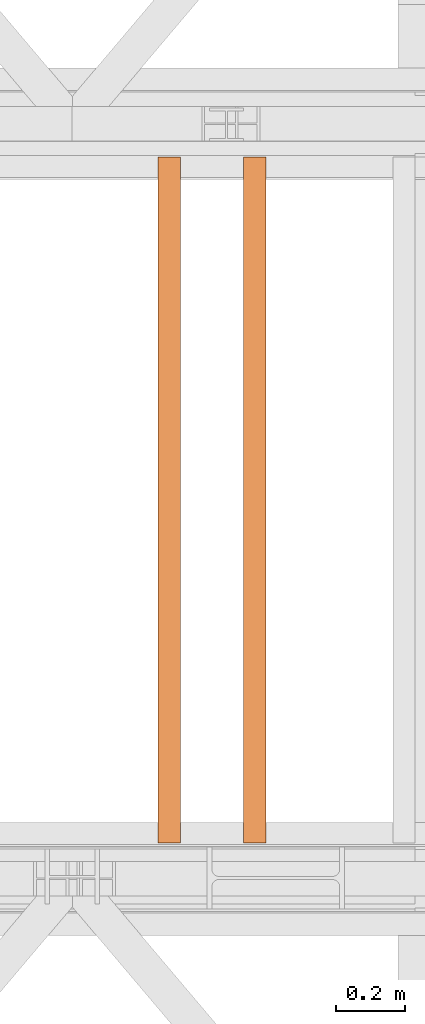
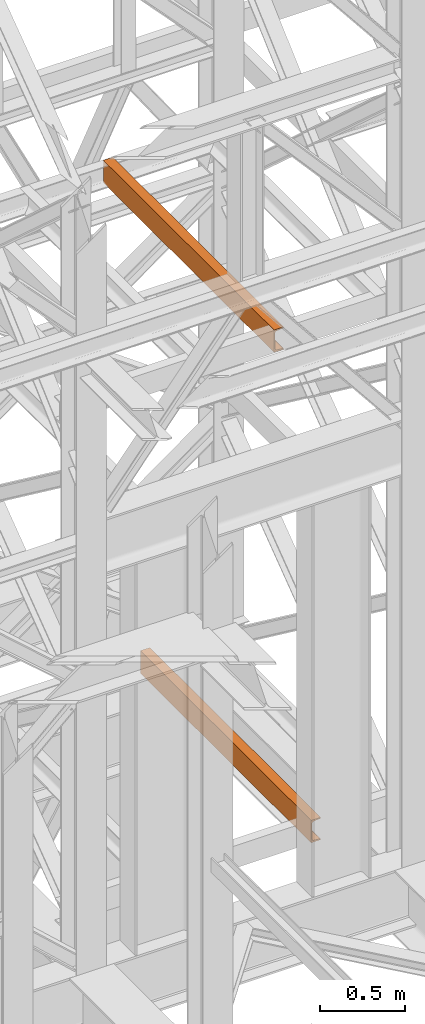
# One storey, part 181 of 208: 2 proxies.
"""IFC2X3 building model written with IfcOpenShell, lengths in millimetres."""

from ifc_helpers import new_model, entity, si_unit, converted_unit, frame, origin, origin_with_axes, place, context, subcontext, project, spatial, faceted_brep, element, save


model = new_model("IFC2X3")

# Units and contexts
model_context = context("Model", 3, precision=1e-05, world=origin())
plan_context = context("Plan", 3, precision=1e-05, world=origin())
body_context = subcontext(model_context, "Body", "Model", "MODEL_VIEW")
ifc_project = project(units=[si_unit("LENGTHUNIT", "METRE", prefix="MILLI"), converted_unit("PLANEANGLEUNIT", "DEGREE", entity("IfcPlaneAngleMeasure", 0.0174532925199433), si_unit("PLANEANGLEUNIT", "RADIAN"), dimensions=[0, 0, 0, 0, 0, 0, 0]), si_unit("AREAUNIT", "SQUARE_METRE"), si_unit("VOLUMEUNIT", "CUBIC_METRE")], contexts=[model_context, plan_context])

# Building, storey
building_placement = place(None, origin())
building = spatial("IfcBuilding", under=ifc_project, at=building_placement, CompositionType="COMPLEX")
storey_placement = place(building_placement, origin_with_axes())
storey = spatial("IfcBuildingStorey", under=building, at=storey_placement, Name="Geschoss", CompositionType="ELEMENT")

# Proxies
proxy_1_placement = place(storey_placement, frame((7943.302373794972, -15857.57439274273, 9109.989999999998), z_axis=(0.0, 0.0, 1.0), x_axis=(1.0, 0.0, 0.0)))
element("IfcBuildingElementProxy", 1, at=proxy_1_placement, inside=storey, context=body_context, shape_type="Brep", body=[
    faceted_brep([(0.01000000000203727, 2000.009997019768, 160.0100000000002), (65.01000000000204, 2000.009997019768, 160.0100000000002), (65.01000000000022, 0.01000000000021828, 160.0100000000002), (0.01000000000021828, 0.01000000000021828, 160.0100000000002), (65.01000000000204, 2000.009997019768, 160.0100000000002), (65.01000000000204, 2000.009997019768, 156.8875719297539), (65.01000000000022, 0.01000000000021828, 156.8875719297539), (65.01000000000022, 0.01000000000021828, 160.0100000000002), (65.01000000000204, 2000.009997019768, 156.8875719297539), (64.76726342282927, 2000.009997019768, 155.2717110918293), (64.76726342282745, 0.01000000000021828, 155.2717110918293), (65.01000000000022, 0.01000000000021828, 156.8875719297539), (64.76726342282927, 2000.009997019768, 155.2717110918293), (64.06053228585733, 2000.009997019768, 153.7984655565542), (64.06053228585915, 0.01000000000021828, 153.7984655565542), (64.76726342282745, 0.01000000000021828, 155.2717110918293), (64.06053228585733, 2000.009997019768, 153.7984655565542), (62.95215163847024, 2000.009997019768, 152.5978732961266), (62.95215163846842, 0.01000000000021828, 152.5978732961266), (64.06053228585915, 0.01000000000021828, 153.7984655565542), (62.95215163847024, 2000.009997019768, 152.5978732961266), (61.53995641148504, 2000.009997019768, 151.7759086082897), (61.53995641148322, 0.01000000000021828, 151.7759086082897), (62.95215163846842, 0.01000000000021828, 152.5978732961266), (61.53995641148504, 2000.009997019768, 151.7759086082897), (59.9485987225562, 2000.009997019768, 151.4050878978051), (59.94859872255438, 0.01000000000021828, 151.4050878978051), (61.53995641148322, 0.01000000000021828, 151.7759086082897), (59.9485987225562, 2000.009997019768, 151.4050878978051), (17.1726751660317, 2000.009997019768, 147.9830140132835), (17.17267516602988, 0.01000000000021828, 147.9830140132835), (59.94859872255438, 0.01000000000021828, 151.4050878978051), (17.1726751660317, 2000.009997019768, 147.9830140132835), (14.20840820801095, 2000.009997019768, 147.318026761528), (14.20840820800913, 0.01000000000021828, 147.318026761528), (17.17267516602988, 0.01000000000021828, 147.9830140132835), (14.20840820801095, 2000.009997019768, 147.318026761528), (11.43861959928836, 2000.009997019768, 145.7058782528511), (11.43861959929018, 0.01000000000021828, 145.7058782528511), (14.20840820800913, 0.01000000000021828, 147.318026761528), (11.43861959928836, 2000.009997019768, 145.7058782528511), (9.3226201815487, 2000.009997019768, 143.4138384829421), (9.322620181546881, 0.01000000000021828, 143.4138384829421), (11.43861959929018, 0.01000000000021828, 145.7058782528511), (9.3226201815487, 2000.009997019768, 143.4138384829421), (7.973406192788389, 2000.009997019768, 140.6012788246917), (7.97340619278657, 0.01000000000021828, 140.6012788246917), (9.322620181546881, 0.01000000000021828, 143.4138384829421), (7.973406192788389, 2000.009997019768, 140.6012788246917), (7.510000000002037, 2000.009997019768, 137.5164535886543), (7.510000000000218, 0.01000000000021828, 137.5164535886543), (7.97340619278657, 0.01000000000021828, 140.6012788246917), (7.510000000002037, 2000.009997019768, 137.5164535886543), (7.510000000002037, 2000.009997019768, 22.503546411348), (7.510000000000218, 0.01000000000021828, 22.503546411348), (7.510000000000218, 0.01000000000021828, 137.5164535886543), (7.510000000002037, 2000.009997019768, 22.503546411348), (7.973406192788389, 2000.009997019768, 19.41872117530875), (7.97340619278657, 0.01000000000021828, 19.41872117530875), (7.510000000000218, 0.01000000000021828, 22.503546411348), (7.973406192788389, 2000.009997019768, 19.41872117530875), (9.3226201815487, 2000.009997019768, 16.60616151705835), (9.322620181546881, 0.01000000000021828, 16.60616151705835), (7.97340619278657, 0.01000000000021828, 19.41872117530875), (9.3226201815487, 2000.009997019768, 16.60616151705835), (11.43861959928836, 2000.009997019768, 14.31412174714933), (11.43861959929018, 0.01000000000021828, 14.31412174714933), (9.322620181546881, 0.01000000000021828, 16.60616151705835), (11.43861959928836, 2000.009997019768, 14.31412174714933), (14.13462866898408, 2000.009997019768, 12.74491643400688), (14.1346286689859, 0.01000000000021828, 12.74491643400688), (11.43861959929018, 0.01000000000021828, 14.31412174714933), (14.13462866898408, 2000.009997019768, 12.74491643400688), (17.1726751660317, 2000.009997019768, 12.03698598671872), (17.17267516602988, 0.01000000000021828, 12.03698598671872), (14.1346286689859, 0.01000000000021828, 12.74491643400688), (17.1726751660317, 2000.009997019768, 12.03698598671872), (59.9485987225562, 2000.009997019768, 8.614912102195376), (59.94859872255438, 0.01000000000021828, 8.614912102195376), (17.17267516602988, 0.01000000000021828, 12.03698598671872), (59.9485987225562, 2000.009997019768, 8.614912102195376), (61.53995641148504, 2000.009997019768, 8.244091391710754), (61.53995641148322, 0.01000000000021828, 8.244091391710754), (59.94859872255438, 0.01000000000021828, 8.614912102195376), (61.53995641148504, 2000.009997019768, 8.244091391710754), (62.95215163847024, 2000.009997019768, 7.422126703873801), (62.95215163846842, 0.01000000000021828, 7.422126703873801), (61.53995641148322, 0.01000000000021828, 8.244091391710754), (62.95215163847024, 2000.009997019768, 7.422126703873801), (64.06053228585733, 2000.009997019768, 6.221534443446217), (64.06053228585915, 0.01000000000021828, 6.221534443446217), (62.95215163846842, 0.01000000000021828, 7.422126703873801), (64.06053228585733, 2000.009997019768, 6.221534443446217), (64.76726342282927, 2000.009997019768, 4.748288908172981), (64.76726342282745, 0.01000000000021828, 4.748288908172981), (64.06053228585915, 0.01000000000021828, 6.221534443446217), (64.76726342282927, 2000.009997019768, 4.748288908172981), (65.01000000000204, 2000.009997019768, 0.01000000000021828), (65.01000000000022, 0.01000000000021828, 0.01000000000021828), (64.76726342282745, 0.01000000000021828, 4.748288908172981), (65.01000000000204, 2000.009997019768, 0.01000000000021828), (0.01000000000203727, 2000.009997019768, 0.01000000000021828), (0.01000000000021828, 0.01000000000021828, 0.01000000000021828), (65.01000000000022, 0.01000000000021828, 0.01000000000021828), (0.01000000000203727, 2000.009997019768, 0.01000000000021828), (0.01000000000203727, 2000.009997019768, 160.0100000000002), (0.01000000000021828, 0.01000000000021828, 160.0100000000002), (0.01000000000021828, 0.01000000000021828, 0.01000000000021828), (0.01000000000203727, 2000.009997019768, 160.0100000000002), (0.01000000000203727, 2000.009997019768, 0.01000000000021828), (65.01000000000204, 2000.009997019768, 0.01000000000021828), (64.76726342282927, 2000.009997019768, 4.748288908172981), (64.06053228585733, 2000.009997019768, 6.221534443446217), (62.95215163847024, 2000.009997019768, 7.422126703873801), (61.53995641148504, 2000.009997019768, 8.244091391710754), (59.9485987225562, 2000.009997019768, 8.614912102195376), (17.1726751660317, 2000.009997019768, 12.03698598671872), (14.13462866898408, 2000.009997019768, 12.74491643400688), (11.43861959928836, 2000.009997019768, 14.31412174714933), (9.3226201815487, 2000.009997019768, 16.60616151705835), (7.973406192788389, 2000.009997019768, 19.41872117530875), (7.510000000002037, 2000.009997019768, 22.503546411348), (7.510000000002037, 2000.009997019768, 137.5164535886543), (7.973406192788389, 2000.009997019768, 140.6012788246917), (9.3226201815487, 2000.009997019768, 143.4138384829421), (11.43861959928836, 2000.009997019768, 145.7058782528511), (14.20840820801095, 2000.009997019768, 147.318026761528), (17.1726751660317, 2000.009997019768, 147.9830140132835), (59.9485987225562, 2000.009997019768, 151.4050878978051), (61.53995641148504, 2000.009997019768, 151.7759086082897), (62.95215163847024, 2000.009997019768, 152.5978732961266), (64.06053228585733, 2000.009997019768, 153.7984655565542), (64.76726342282927, 2000.009997019768, 155.2717110918293), (65.01000000000204, 2000.009997019768, 156.8875719297539), (65.01000000000204, 2000.009997019768, 160.0100000000002), (0.01000000000021828, 0.01000000000021828, 160.0100000000002), (65.01000000000022, 0.01000000000021828, 160.0100000000002), (65.01000000000022, 0.01000000000021828, 156.8875719297539), (64.76726342282745, 0.01000000000021828, 155.2717110918293), (64.06053228585915, 0.01000000000021828, 153.7984655565542), (62.95215163846842, 0.01000000000021828, 152.5978732961266), (61.53995641148322, 0.01000000000021828, 151.7759086082897), (59.94859872255438, 0.01000000000021828, 151.4050878978051), (17.17267516602988, 0.01000000000021828, 147.9830140132835), (14.20840820800913, 0.01000000000021828, 147.318026761528), (11.43861959929018, 0.01000000000021828, 145.7058782528511), (9.322620181546881, 0.01000000000021828, 143.4138384829421), (7.97340619278657, 0.01000000000021828, 140.6012788246917), (7.510000000000218, 0.01000000000021828, 137.5164535886543), (7.510000000000218, 0.01000000000021828, 22.503546411348), (7.97340619278657, 0.01000000000021828, 19.41872117530875), (9.322620181546881, 0.01000000000021828, 16.60616151705835), (11.43861959929018, 0.01000000000021828, 14.31412174714933), (14.1346286689859, 0.01000000000021828, 12.74491643400688), (17.17267516602988, 0.01000000000021828, 12.03698598671872), (59.94859872255438, 0.01000000000021828, 8.614912102195376), (61.53995641148322, 0.01000000000021828, 8.244091391710754), (62.95215163846842, 0.01000000000021828, 7.422126703873801), (64.06053228585915, 0.01000000000021828, 6.221534443446217), (64.76726342282745, 0.01000000000021828, 4.748288908172981), (65.01000000000022, 0.01000000000021828, 0.01000000000021828), (0.01000000000021828, 0.01000000000021828, 0.01000000000021828)], [[[0, 1, 2, 3]], [[4, 5, 6, 7]], [[8, 9, 10, 11]], [[12, 13, 14, 15]], [[16, 17, 18, 19]], [[20, 21, 22, 23]], [[24, 25, 26, 27]], [[28, 29, 30, 31]], [[32, 33, 34, 35]], [[36, 37, 38, 39]], [[40, 41, 42, 43]], [[44, 45, 46, 47]], [[48, 49, 50, 51]], [[52, 53, 54, 55]], [[56, 57, 58, 59]], [[60, 61, 62, 63]], [[64, 65, 66, 67]], [[68, 69, 70, 71]], [[72, 73, 74, 75]], [[76, 77, 78, 79]], [[80, 81, 82, 83]], [[84, 85, 86, 87]], [[88, 89, 90, 91]], [[92, 93, 94, 95]], [[96, 97, 98, 99]], [[100, 101, 102, 103]], [[104, 105, 106, 107]], [[108, 109, 110, 111, 112, 113, 114, 115, 116, 117, 118, 119, 120, 121, 122, 123, 124, 125, 126, 127, 128, 129, 130, 131, 132, 133, 134]], [[135, 136, 137, 138, 139, 140, 141, 142, 143, 144, 145, 146, 147, 148, 149, 150, 151, 152, 153, 154, 155, 156, 157, 158, 159, 160, 161]]], orient=[[False], [False], [False], [False], [False], [False], [False], [False], [False], [False], [False], [False], [False], [False], [False], [False], [False], [False], [False], [False], [False], [False], [False], [False], [False], [False], [False], [False], [False]]),
])
proxy_2_placement = place(storey_placement, frame((8193.254968528667, -15857.57439274273, 5518.360005364418), z_axis=(0.0, 0.0, 1.0), x_axis=(1.0, 0.0, 0.0)))
element("IfcBuildingElementProxy", 2, at=proxy_2_placement, inside=storey, context=body_context, shape_type="Brep", body=[
    faceted_brep([(0.01000000000021828, 2000.009997019768, 160.0100000000002), (65.01000000000022, 2000.009997019768, 160.0100000000002), (65.0099999999984, 0.01000000000021828, 160.0100000000002), (0.00999999999839929, 0.01000000000021828, 160.0100000000002), (65.01000000000022, 2000.009997019768, 160.0100000000002), (65.01000000000022, 2000.009997019768, 156.8875719297539), (65.0099999999984, 0.01000000000021828, 156.8875719297539), (65.0099999999984, 0.01000000000021828, 160.0100000000002), (65.01000000000022, 2000.009997019768, 156.8875719297539), (64.76726342282745, 2000.009997019768, 155.2717110918293), (64.76726342282564, 0.01000000000021828, 155.2717110918293), (65.0099999999984, 0.01000000000021828, 156.8875719297539), (64.76726342282745, 2000.009997019768, 155.2717110918293), (64.06053228585552, 2000.009997019768, 153.7984655565542), (64.06053228585733, 0.01000000000021828, 153.7984655565542), (64.76726342282564, 0.01000000000021828, 155.2717110918293), (64.06053228585552, 2000.009997019768, 153.7984655565542), (62.95215163846842, 2000.009997019768, 152.5978732961266), (62.9521516384666, 0.01000000000021828, 152.5978732961266), (64.06053228585733, 0.01000000000021828, 153.7984655565542), (62.95215163846842, 2000.009997019768, 152.5978732961266), (61.53995641148322, 2000.009997019768, 151.7759086082897), (61.5399564114814, 0.01000000000021828, 151.7759086082897), (62.9521516384666, 0.01000000000021828, 152.5978732961266), (61.53995641148322, 2000.009997019768, 151.7759086082897), (59.94859872255438, 2000.009997019768, 151.4050878978051), (59.94859872255256, 0.01000000000021828, 151.4050878978051), (61.5399564114814, 0.01000000000021828, 151.7759086082897), (59.94859872255438, 2000.009997019768, 151.4050878978051), (17.17267516602988, 2000.009997019768, 147.9830140132835), (17.17267516602806, 0.01000000000021828, 147.9830140132835), (59.94859872255256, 0.01000000000021828, 151.4050878978051), (17.17267516602988, 2000.009997019768, 147.9830140132835), (14.20840820800913, 2000.009997019768, 147.318026761528), (14.20840820800731, 0.01000000000021828, 147.318026761528), (17.17267516602806, 0.01000000000021828, 147.9830140132835), (14.20840820800913, 2000.009997019768, 147.318026761528), (11.43861959928654, 2000.009997019768, 145.7058782528511), (11.43861959928836, 0.01000000000021828, 145.7058782528511), (14.20840820800731, 0.01000000000021828, 147.318026761528), (11.43861959928654, 2000.009997019768, 145.7058782528511), (9.322620181546881, 2000.009997019768, 143.4138384829421), (9.322620181545062, 0.01000000000021828, 143.4138384829421), (11.43861959928836, 0.01000000000021828, 145.7058782528511), (9.322620181546881, 2000.009997019768, 143.4138384829421), (7.97340619278657, 2000.009997019768, 140.6012788246917), (7.973406192784751, 0.01000000000021828, 140.6012788246917), (9.322620181545062, 0.01000000000021828, 143.4138384829421), (7.97340619278657, 2000.009997019768, 140.6012788246917), (7.510000000000218, 2000.009997019768, 137.5164535886543), (7.509999999998399, 0.01000000000021828, 137.5164535886543), (7.973406192784751, 0.01000000000021828, 140.6012788246917), (7.510000000000218, 2000.009997019768, 137.5164535886543), (7.510000000000218, 2000.009997019768, 22.503546411348), (7.509999999998399, 0.01000000000021828, 22.503546411348), (7.509999999998399, 0.01000000000021828, 137.5164535886543), (7.510000000000218, 2000.009997019768, 22.503546411348), (7.97340619278657, 2000.009997019768, 19.41872117530875), (7.973406192784751, 0.01000000000021828, 19.41872117530875), (7.509999999998399, 0.01000000000021828, 22.503546411348), (7.97340619278657, 2000.009997019768, 19.41872117530875), (9.322620181546881, 2000.009997019768, 16.60616151705835), (9.322620181545062, 0.01000000000021828, 16.60616151705835), (7.973406192784751, 0.01000000000021828, 19.41872117530875), (9.322620181546881, 2000.009997019768, 16.60616151705835), (11.43861959928654, 2000.009997019768, 14.31412174714933), (11.43861959928836, 0.01000000000021828, 14.31412174714933), (9.322620181545062, 0.01000000000021828, 16.60616151705835), (11.43861959928654, 2000.009997019768, 14.31412174714933), (14.13462866898226, 2000.009997019768, 12.74491643400688), (14.13462866898408, 0.01000000000021828, 12.74491643400688), (11.43861959928836, 0.01000000000021828, 14.31412174714933), (14.13462866898226, 2000.009997019768, 12.74491643400688), (17.17267516602988, 2000.009997019768, 12.03698598671872), (17.17267516602806, 0.01000000000021828, 12.03698598671872), (14.13462866898408, 0.01000000000021828, 12.74491643400688), (17.17267516602988, 2000.009997019768, 12.03698598671872), (59.94859872255438, 2000.009997019768, 8.614912102195376), (59.94859872255256, 0.01000000000021828, 8.614912102195376), (17.17267516602806, 0.01000000000021828, 12.03698598671872), (59.94859872255438, 2000.009997019768, 8.614912102195376), (61.53995641148322, 2000.009997019768, 8.244091391710754), (61.5399564114814, 0.01000000000021828, 8.244091391710754), (59.94859872255256, 0.01000000000021828, 8.614912102195376), (61.53995641148322, 2000.009997019768, 8.244091391710754), (62.95215163846842, 2000.009997019768, 7.422126703873801), (62.9521516384666, 0.01000000000021828, 7.422126703873801), (61.5399564114814, 0.01000000000021828, 8.244091391710754), (62.95215163846842, 2000.009997019768, 7.422126703873801), (64.06053228585552, 2000.009997019768, 6.221534443446217), (64.06053228585733, 0.01000000000021828, 6.221534443446217), (62.9521516384666, 0.01000000000021828, 7.422126703873801), (64.06053228585552, 2000.009997019768, 6.221534443446217), (64.76726342282745, 2000.009997019768, 4.748288908172981), (64.76726342282564, 0.01000000000021828, 4.748288908172981), (64.06053228585733, 0.01000000000021828, 6.221534443446217), (64.76726342282745, 2000.009997019768, 4.748288908172981), (65.01000000000022, 2000.009997019768, 0.01000000000021828), (65.0099999999984, 0.01000000000021828, 0.01000000000021828), (64.76726342282564, 0.01000000000021828, 4.748288908172981), (65.01000000000022, 2000.009997019768, 0.01000000000021828), (0.01000000000021828, 2000.009997019768, 0.01000000000021828), (0.00999999999839929, 0.01000000000021828, 0.01000000000021828), (65.0099999999984, 0.01000000000021828, 0.01000000000021828), (0.01000000000021828, 2000.009997019768, 0.01000000000021828), (0.01000000000021828, 2000.009997019768, 160.0100000000002), (0.00999999999839929, 0.01000000000021828, 160.0100000000002), (0.00999999999839929, 0.01000000000021828, 0.01000000000021828), (0.01000000000021828, 2000.009997019768, 160.0100000000002), (0.01000000000021828, 2000.009997019768, 0.01000000000021828), (65.01000000000022, 2000.009997019768, 0.01000000000021828), (64.76726342282745, 2000.009997019768, 4.748288908172981), (64.06053228585552, 2000.009997019768, 6.221534443446217), (62.95215163846842, 2000.009997019768, 7.422126703873801), (61.53995641148322, 2000.009997019768, 8.244091391710754), (59.94859872255438, 2000.009997019768, 8.614912102195376), (17.17267516602988, 2000.009997019768, 12.03698598671872), (14.13462866898226, 2000.009997019768, 12.74491643400688), (11.43861959928654, 2000.009997019768, 14.31412174714933), (9.322620181546881, 2000.009997019768, 16.60616151705835), (7.97340619278657, 2000.009997019768, 19.41872117530875), (7.510000000000218, 2000.009997019768, 22.503546411348), (7.510000000000218, 2000.009997019768, 137.5164535886543), (7.97340619278657, 2000.009997019768, 140.6012788246917), (9.322620181546881, 2000.009997019768, 143.4138384829421), (11.43861959928654, 2000.009997019768, 145.7058782528511), (14.20840820800913, 2000.009997019768, 147.318026761528), (17.17267516602988, 2000.009997019768, 147.9830140132835), (59.94859872255438, 2000.009997019768, 151.4050878978051), (61.53995641148322, 2000.009997019768, 151.7759086082897), (62.95215163846842, 2000.009997019768, 152.5978732961266), (64.06053228585552, 2000.009997019768, 153.7984655565542), (64.76726342282745, 2000.009997019768, 155.2717110918293), (65.01000000000022, 2000.009997019768, 156.8875719297539), (65.01000000000022, 2000.009997019768, 160.0100000000002), (0.00999999999839929, 0.01000000000021828, 160.0100000000002), (65.0099999999984, 0.01000000000021828, 160.0100000000002), (65.0099999999984, 0.01000000000021828, 156.8875719297539), (64.76726342282564, 0.01000000000021828, 155.2717110918293), (64.06053228585733, 0.01000000000021828, 153.7984655565542), (62.9521516384666, 0.01000000000021828, 152.5978732961266), (61.5399564114814, 0.01000000000021828, 151.7759086082897), (59.94859872255256, 0.01000000000021828, 151.4050878978051), (17.17267516602806, 0.01000000000021828, 147.9830140132835), (14.20840820800731, 0.01000000000021828, 147.318026761528), (11.43861959928836, 0.01000000000021828, 145.7058782528511), (9.322620181545062, 0.01000000000021828, 143.4138384829421), (7.973406192784751, 0.01000000000021828, 140.6012788246917), (7.509999999998399, 0.01000000000021828, 137.5164535886543), (7.509999999998399, 0.01000000000021828, 22.503546411348), (7.973406192784751, 0.01000000000021828, 19.41872117530875), (9.322620181545062, 0.01000000000021828, 16.60616151705835), (11.43861959928836, 0.01000000000021828, 14.31412174714933), (14.13462866898408, 0.01000000000021828, 12.74491643400688), (17.17267516602806, 0.01000000000021828, 12.03698598671872), (59.94859872255256, 0.01000000000021828, 8.614912102195376), (61.5399564114814, 0.01000000000021828, 8.244091391710754), (62.9521516384666, 0.01000000000021828, 7.422126703873801), (64.06053228585733, 0.01000000000021828, 6.221534443446217), (64.76726342282564, 0.01000000000021828, 4.748288908172981), (65.0099999999984, 0.01000000000021828, 0.01000000000021828), (0.00999999999839929, 0.01000000000021828, 0.01000000000021828)], [[[0, 1, 2, 3]], [[4, 5, 6, 7]], [[8, 9, 10, 11]], [[12, 13, 14, 15]], [[16, 17, 18, 19]], [[20, 21, 22, 23]], [[24, 25, 26, 27]], [[28, 29, 30, 31]], [[32, 33, 34, 35]], [[36, 37, 38, 39]], [[40, 41, 42, 43]], [[44, 45, 46, 47]], [[48, 49, 50, 51]], [[52, 53, 54, 55]], [[56, 57, 58, 59]], [[60, 61, 62, 63]], [[64, 65, 66, 67]], [[68, 69, 70, 71]], [[72, 73, 74, 75]], [[76, 77, 78, 79]], [[80, 81, 82, 83]], [[84, 85, 86, 87]], [[88, 89, 90, 91]], [[92, 93, 94, 95]], [[96, 97, 98, 99]], [[100, 101, 102, 103]], [[104, 105, 106, 107]], [[108, 109, 110, 111, 112, 113, 114, 115, 116, 117, 118, 119, 120, 121, 122, 123, 124, 125, 126, 127, 128, 129, 130, 131, 132, 133, 134]], [[135, 136, 137, 138, 139, 140, 141, 142, 143, 144, 145, 146, 147, 148, 149, 150, 151, 152, 153, 154, 155, 156, 157, 158, 159, 160, 161]]], orient=[[False], [False], [False], [False], [False], [False], [False], [False], [False], [False], [False], [False], [False], [False], [False], [False], [False], [False], [False], [False], [False], [False], [False], [False], [False], [False], [False], [False], [False]]),
])

save(model, "model.ifc")
